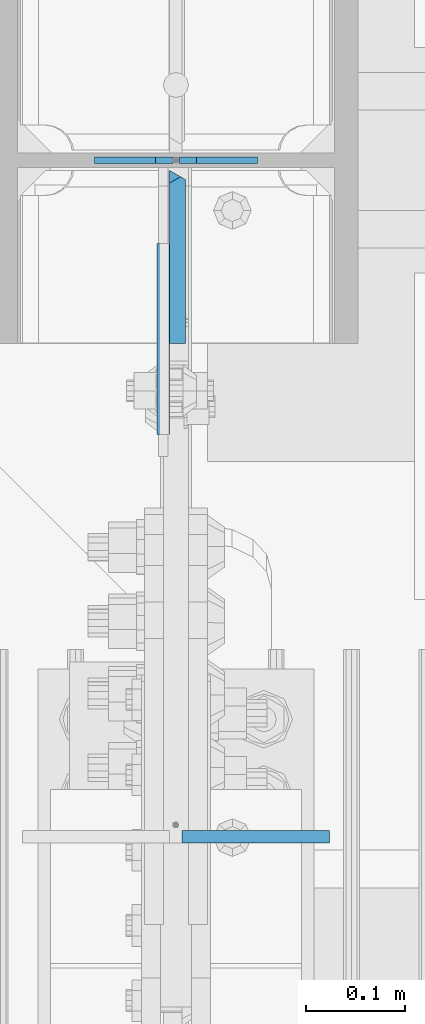
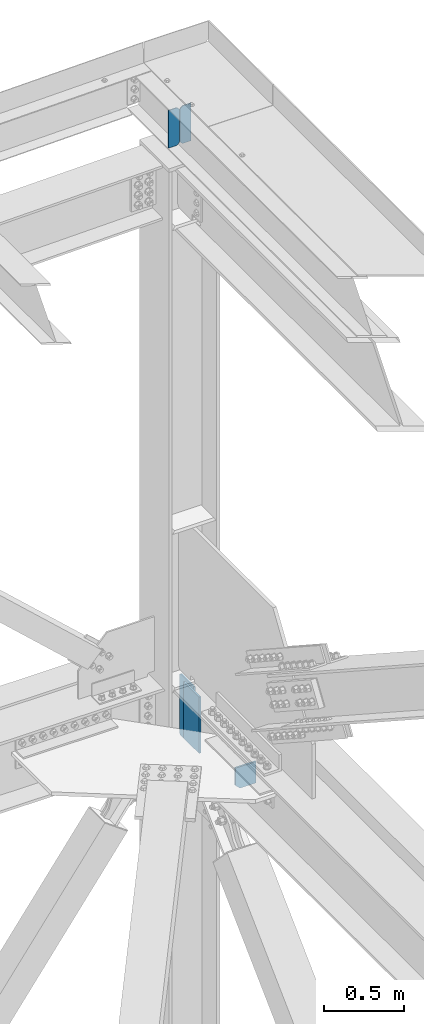
# One storey, part 3656 of 3843: 5 plates, 3 elements without a shape of their own.
"""IFC2X3 building model written with IfcOpenShell, lengths in millimetres."""

from ifc_helpers import new_model, si_unit, frame, origin_with_axes, place, context, subcontext, project, spatial, faceted_brep, material, type_object, element, aggregate, save


model = new_model("IFC2X3")

# Units and contexts
model_context = context("Model", 3, precision=1e-05, world=origin_with_axes())
body_context = subcontext(model_context, "Body", "Model", "MODEL_VIEW")
ifc_project = project(units=[si_unit("LENGTHUNIT", "METRE", prefix="MILLI"), si_unit("AREAUNIT", "SQUARE_METRE"), si_unit("VOLUMEUNIT", "CUBIC_METRE"), si_unit("MASSUNIT", "GRAM", prefix="KILO"), si_unit("TIMEUNIT", "SECOND"), si_unit("PLANEANGLEUNIT", "RADIAN"), si_unit("SOLIDANGLEUNIT", "STERADIAN"), si_unit("THERMODYNAMICTEMPERATUREUNIT", "DEGREE_CELSIUS"), si_unit("LUMINOUSINTENSITYUNIT", "LUMEN")], contexts=[model_context])

# Site, building, storey
site_placement = place(None, origin_with_axes())
site = spatial("IfcSite", under=ifc_project, at=site_placement, CompositionType="ELEMENT")
building_placement = place(site_placement, origin_with_axes())
building = spatial("IfcBuilding", under=site, at=building_placement, Name="Undefined", CompositionType="ELEMENT")
storey_placement = place(building_placement, origin_with_axes())
storey = spatial("IfcBuildingStorey", under=building, at=storey_placement, Name="Undefined", CompositionType="ELEMENT", Elevation=0.0)

# Assembly, plates
assembly_1_placement = place(storey_placement, origin_with_axes())
assembly_1 = element("IfcElementAssembly", 1, at=assembly_1_placement, inside=storey, Name="BEAM", AssemblyPlace="NOTDEFINED", PredefinedType="RIGID_FRAME")
ifc_material = material(Name="STEEL/A572-50")
plate_type_1 = type_object("IfcPlateType", PredefinedType="NOTDEFINED")
plate_1_placement = place(assembly_1_placement, frame((85731.3500000034, 104559.100000002, 46467.7125000001), z_axis=(0.0, 0.0, 1.0), x_axis=(-1.0, 0.0, 0.0)))
plate_1 = element("IfcPlate", 2, at=plate_1_placement, type_object=plate_type_1, material=ifc_material, Name="STIFFENER", context=body_context, shape_type="Brep", body=[
    faceted_brep([(0.0, -3.17499999999927, 0.0), (6.83940015733242e-10, -3.17499999996653, 288.924999998613), (6.54836185276508e-10, 3.17500000001746, 288.924999998591), (0.0, 3.17499999999927, 0.0), (61.9125003828667, -3.17499999997744, 288.924999998599), (61.9125003828522, 3.17500000002838, 288.924999998584), (79.3750000013097, -3.17499999997744, 271.462500380039), (79.375000001266, 3.17500000002838, 271.462500380017), (79.375000000713, -3.17499999999927, 17.4624996185448), (79.3750000006694, 3.17500000000291, 17.462499618523), (61.9125003821828, -3.17499999999563, -1.45519152283669e-11), (61.9125003821682, 3.17500000000655, -2.91038304567337e-11)], [[[0, 1, 2, 3]], [[1, 4, 5, 2]], [[4, 6, 7, 5]], [[6, 8, 9, 7]], [[8, 10, 11, 9]], [[10, 0, 3, 11]], [[5, 7, 9, 11, 3, 2]], [[10, 8, 6, 4, 1, 0]]]),
])
plate_2_placement = place(assembly_1_placement, frame((85645.6250000033, 104559.100000002, 46467.7125000001), z_axis=(0.0, 0.0, 1.0), x_axis=(-1.0, 0.0, 0.0)))
plate_2 = element("IfcPlate", 3, at=plate_2_placement, type_object=plate_type_1, material=ifc_material, Name="STIFFENER", context=body_context, shape_type="Brep", body=[
    faceted_brep([(5.82076609134674e-11, -3.17499999999927, 17.4624996185667), (6.25732354819775e-10, -3.17499999997744, 271.462500380054), (5.82076609134674e-10, 3.17500000002474, 271.462500380039), (0.0, 3.17500000000655, 17.4624996185521), (17.462499619156, -3.17499999997744, 288.924999998606), (17.4624996191269, 3.17500000002474, 288.924999998591), (79.3750000013242, -3.17500000025029, 288.924999998591), (79.3750000013097, 3.1749999997337, 288.92499999857), (79.3750000006548, -3.17500000026484, -2.18278728425503e-11), (79.3750000006403, 3.17499999969732, -2.91038304567337e-11), (17.4624996184866, -3.17500000000291, 7.27595761418343e-12), (17.462499618443, 3.17500000000291, -7.27595761418343e-12)], [[[0, 1, 2, 3]], [[1, 4, 5, 2]], [[4, 6, 7, 5]], [[6, 8, 9, 7]], [[8, 10, 11, 9]], [[10, 0, 3, 11]], [[5, 7, 9, 11, 3, 2]], [[10, 8, 6, 4, 1, 0]]]),
])
aggregate(assembly_1, [plate_1, plate_2])

# Assembly, plate
assembly_2_placement = place(storey_placement, origin_with_axes())
assembly_2 = element("IfcElementAssembly", 4, at=assembly_2_placement, inside=storey, Name="BEAM", AssemblyPlace="NOTDEFINED", PredefinedType="RIGID_FRAME")
plate_type_2 = type_object("IfcPlateType", PredefinedType="NOTDEFINED")
plate_3_placement = place(assembly_2_placement, frame((85655.15, 103874.356415715, 42110.025), z_axis=(0.0, 0.0, -1.0), x_axis=(1.0, 0.0, 0.0)))
plate_3 = element("IfcPlate", 5, at=plate_3_placement, type_object=plate_type_2, material=ifc_material, Name="PLATE", context=body_context, shape_type="Brep", body=[
    faceted_brep([(0.0, -6.3499999046162, 0.0), (0.0, -6.35000000000582, 131.762499999997), (0.0, 6.35000000000582, 131.762499999997), (7.27595761418343e-12, 6.3499999046162, 0.0), (31.75, -6.35000000000582, 163.512499999997), (31.75, 6.35000000000582, 163.512499999997), (149.224999999991, -6.35000000000582, 163.512499999997), (149.224999999991, 6.35000000000582, 163.512499999997), (149.224999999991, -6.35000000000582, 0.0), (149.224999999991, 6.35000000000582, 0.0)], [[[0, 1, 2, 3]], [[1, 4, 5, 2]], [[4, 6, 7, 5]], [[6, 8, 9, 7]], [[8, 0, 3, 9]], [[5, 7, 9, 3, 2]], [[8, 6, 4, 1, 0]]]),
])
aggregate(assembly_2, [plate_3])

# Assembly, plates
assembly_3_placement = place(storey_placement, origin_with_axes())
assembly_3 = element("IfcElementAssembly", 6, at=assembly_3_placement, inside=storey, Name="COLUMN", AssemblyPlace="NOTDEFINED", PredefinedType="RIGID_FRAME")
plate_type_3 = type_object("IfcPlateType", PredefinedType="NOTDEFINED")
plate_4_placement = place(assembly_3_placement, frame((85650.3875, 104551.956250014, 41976.6750000008), z_axis=(0.0, -0.707106781186682, 0.707106781186413), x_axis=(0.0, -0.707106781186548, -0.707106781186548)))
plate_4 = element("IfcPlate", 7, at=plate_4_placement, type_object=plate_type_3, material=ifc_material, Name="PLATE", context=body_context, shape_type="Brep", body=[
    faceted_brep([(4.49012799309094, -7.9375, 7.27595761418343e-12), (-312.063900203553, -7.9375, 316.554028203769), (-312.063900203248, 3.06102270915289, 325.534284391004), (-308.082273168307, 7.9375, 325.534284391018), (13.470384184775, 7.9375, 3.98162703046546), (13.4703841731916, 3.06102272879798, -7.27595761418343e-12), (-312.06390018767, -7.9375, 334.514540549832), (-197.004368672904, -7.9375, 449.574072064608), (-190.523427061838, 7.9375, 443.093130453524), (22.4506403026729, -7.93750001103617, 0.0), (131.029230272985, 7.9375, 121.540473118737), (137.510171884061, -7.9375, 115.059531507664), (62.3005266916225, 7.9375, 190.269176711488), (62.3005266916225, -7.9375, 190.269176711488), (-171.186132170253, 7.9375, 423.755835579228), (-171.186132170253, -7.9375, 423.755835579228)], [[[0, 1, 2, 3, 4, 5]], [[6, 7, 8, 3, 2]], [[9, 0, 5]], [[10, 11, 9, 5, 4]], [[12, 13, 11, 10]], [[14, 15, 13, 12]], [[15, 14, 8, 7]], [[1, 0, 9, 11, 13, 15, 7, 6]], [[6, 2, 1]], [[8, 14, 12, 10, 4, 3]]]),
])
plate_type_4 = type_object("IfcPlateType", PredefinedType="NOTDEFINED")
plate_5_placement = place(assembly_3_placement, frame((85636.0999999999, 104281.287500426, 42413.2375), z_axis=(0.0, 0.0, -1.0), x_axis=(0.0, 1.0, 0.0)))
plate_5 = element("IfcPlate", 8, at=plate_5_placement, type_object=plate_type_4, material=ifc_material, Name="PLATE", context=body_context, shape_type="Brep", body=[
    faceted_brep([(0.0, -6.3499999046162, 0.0), (0.0, -6.35000000000582, 431.800000000003), (0.0, 6.35000000000582, 431.800000000003), (7.27595761418343e-12, 6.3499999046162, 0.0), (193.674999999996, -6.35000000000582, 431.800000000003), (193.674999999996, 6.35000000000582, 431.800000000003), (193.674999999996, -6.35000000000582, 0.0), (193.674999999996, 6.35000000000582, 0.0)], [[[0, 1, 2, 3]], [[1, 4, 5, 2]], [[4, 6, 7, 5]], [[6, 0, 3, 7]], [[5, 7, 3, 2]], [[6, 4, 1, 0]]]),
])
aggregate(assembly_3, [plate_5, plate_4])

save(model, "model.ifc")
